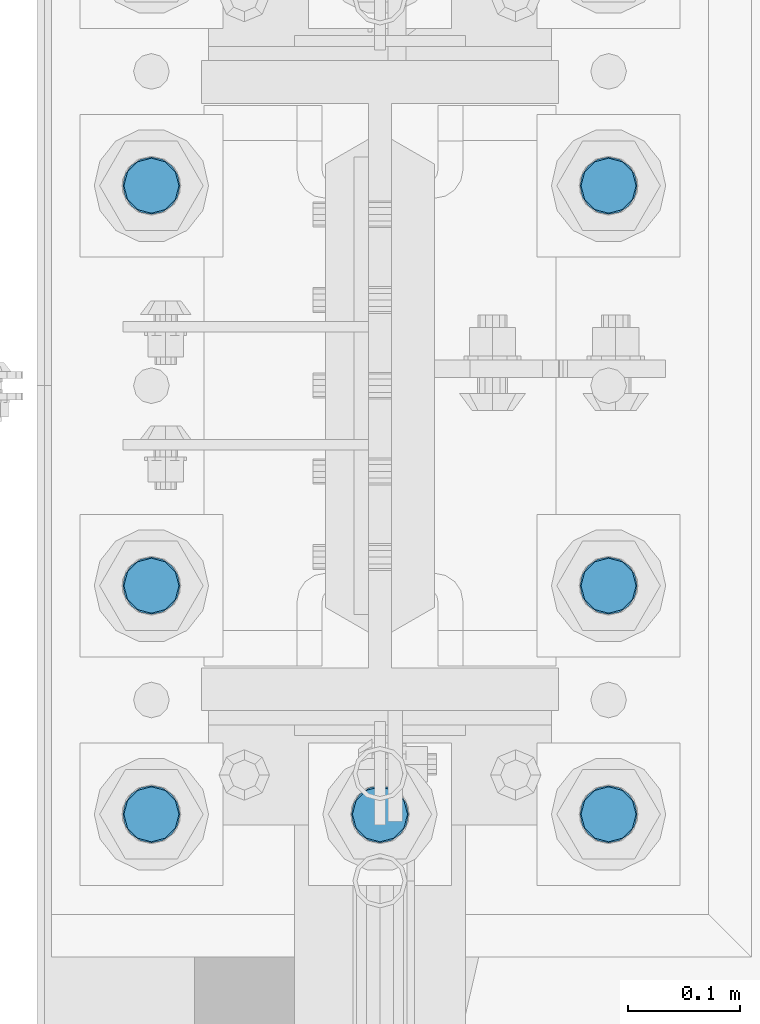
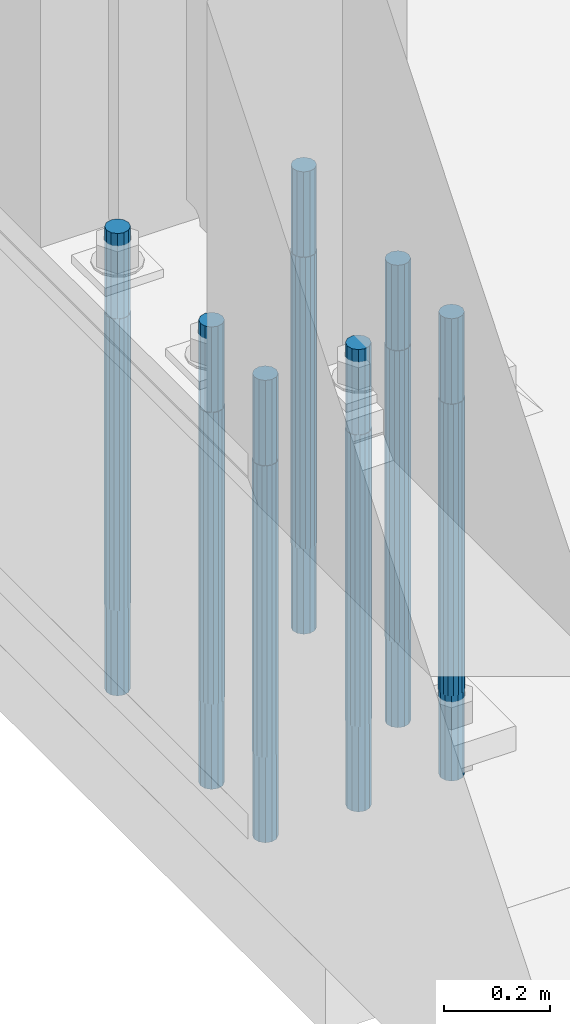
# One storey, part 731 of 1876: 7 columns, 1 element without a shape of its own.
"""IFC2X3 building model written with IfcOpenShell, lengths in millimetres."""

from ifc_helpers import new_model, si_unit, frame, origin_with_axes, place, context, subcontext, project, spatial, faceted_brep, material, type_object, element, aggregate, save


model = new_model("IFC2X3")

# Units and contexts
model_context = context("Model", 3, precision=1e-05, world=origin_with_axes())
body_context = subcontext(model_context, "Body", "Model", "MODEL_VIEW")
ifc_project = project(units=[si_unit("LENGTHUNIT", "METRE", prefix="MILLI"), si_unit("AREAUNIT", "SQUARE_METRE"), si_unit("VOLUMEUNIT", "CUBIC_METRE"), si_unit("MASSUNIT", "GRAM", prefix="KILO"), si_unit("TIMEUNIT", "SECOND"), si_unit("PLANEANGLEUNIT", "RADIAN"), si_unit("SOLIDANGLEUNIT", "STERADIAN"), si_unit("THERMODYNAMICTEMPERATUREUNIT", "DEGREE_CELSIUS"), si_unit("LUMINOUSINTENSITYUNIT", "LUMEN")], contexts=[model_context])

# Site, building, storey
site_placement = place(None, origin_with_axes())
site = spatial("IfcSite", under=ifc_project, at=site_placement, CompositionType="ELEMENT")
building_placement = place(site_placement, origin_with_axes())
building = spatial("IfcBuilding", under=site, at=building_placement, Name="Undefined", CompositionType="ELEMENT")
storey_placement = place(building_placement, origin_with_axes())
storey = spatial("IfcBuildingStorey", under=building, at=storey_placement, Name="Undefined", CompositionType="ELEMENT", Elevation=0.0)

# Assembly, columns
assembly_placement = place(storey_placement, origin_with_axes())
assembly = element("IfcElementAssembly", 1, at=assembly_placement, inside=storey, Name="TEMPLATE", AssemblyPlace="NOTDEFINED", PredefinedType="RIGID_FRAME")
ifc_material = material(Name="STEEL/F1554-GR.105")
column_type = type_object("IfcColumnType", PredefinedType="NOTDEFINED")
column_1_placement = place(assembly_placement, frame((-203.2, 7239.0, 0.0), z_axis=(0.0, -1.0, 0.0), x_axis=(0.0, 0.0, -1.0)))
column_1 = element("IfcColumn", 2, at=column_1_placement, type_object=column_type, material=ifc_material, Name="ANCHOR_BOLTS", context=body_context, shape_type="Brep", body=[
    faceted_brep([(-196.85, -21.217622392719, 12.25), (-196.85, -12.25, 21.2176223927188), (-196.85, 0.0, 24.5), (-196.85, 12.25, 21.2176223927188), (-196.85, 21.217622392719, 12.25), (-196.85, 24.5, 0.0), (-196.85, 21.217622392719, -12.25), (-196.85, 12.25, -21.2176223927188), (-196.85, 0.0, -24.5), (-196.85, -12.25, -21.2176223927188), (-196.85, -21.217622392719, -12.25), (-196.85, -24.5, 0.0), (0.0, 24.5, 0.0), (0.0, 21.217622392719, -12.25), (0.0, 12.25, -21.2176223927188), (0.0, 0.0, -24.5), (0.0, -12.25, -21.2176223927188), (0.0, -21.217622392719, -12.25), (0.0, -24.5, 0.0), (0.0, -21.217622392719, 12.25), (0.0, -12.25, 21.2176223927188), (0.0, 0.0, 24.5), (0.0, 12.25, 21.2176223927188), (0.0, 21.217622392719, 12.25), (0.0, -23.4665401257871, 9.7201591820733), (0.0, -17.9605122421381, 17.9605122421383), (0.0, -9.72015918207308, 23.4665401257867), (0.0, 0.0, 25.4000000000001), (0.0, 9.72015918207308, 23.4665401257867), (0.0, 17.9605122421381, 17.9605122421383), (0.0, 23.4665401257871, 9.7201591820733), (0.0, 25.3999996185339, 9.09494701772928e-13), (0.0, 23.4665401257871, -9.7201591820733), (0.0, 17.9605122421381, -17.9605122421383), (0.0, 9.72015918207308, -23.4665401257867), (0.0, 0.0, -25.4000000000001), (0.0, -9.72015918207308, -23.4665401257867), (0.0, -17.9605122421381, -17.9605122421383), (0.0, -23.4665401257871, -9.7201591820733), (0.0, -25.3999996185375, 0.0), (673.1, -25.3999999999996, 0.0), (673.1, -23.4665401257871, 9.7201591820733), (673.1, -17.9605122421381, 17.9605122421383), (673.1, -9.72015918207308, 23.4665401257867), (673.1, 0.0, 25.4000000000001), (673.1, 9.72015918207308, 23.4665401257867), (673.1, 17.9605122421381, 17.9605122421383), (673.1, 23.4665401257871, 9.7201591820733), (673.1, 25.3999999999996, 0.0), (673.1, 23.4665401257871, -9.7201591820733), (673.1, 17.9605122421381, -17.9605122421383), (673.1, 9.72015918207308, -23.4665401257867), (673.1, 0.0, -25.4000000000001), (673.1, -9.72015918207308, -23.4665401257867), (673.1, -17.9605122421381, -17.9605122421383), (673.1, -23.4665401257871, -9.7201591820733), (673.1, -12.25, 21.2176223927188), (673.1, 0.0, 24.5), (673.1, 12.25, 21.2176223927188), (673.1, 21.217622392719, 12.25), (673.1, 24.5, 0.0), (673.1, 21.217622392719, -12.25), (673.1, 12.25, -21.2176223927188), (673.1, 0.0, -24.5), (673.1, -12.25, -21.2176223927188), (673.1, -21.217622392719, -12.25), (673.1, -24.5, 0.0), (673.1, -21.217622392719, 12.25), (869.95, -12.25, -21.2176223927188), (869.95, 0.0, -24.5), (869.95, 12.25, -21.2176223927188), (869.95, 21.217622392719, -12.25), (869.95, 24.5, 0.0), (869.95, 21.217622392719, 12.25), (869.95, 12.25, 21.2176223927188), (869.95, 0.0, 24.5), (869.95, -12.25, 21.2176223927188), (869.95, -21.217622392719, 12.25), (869.95, -24.5, 0.0), (869.95, -21.217622392719, -12.25)], [[[0, 1, 2, 3, 4, 5, 6, 7, 8, 9, 10, 11]], [[6, 5, 12, 13]], [[7, 6, 13, 14]], [[8, 7, 14, 15]], [[9, 8, 15, 16]], [[10, 9, 16, 17]], [[11, 10, 17, 18]], [[0, 11, 18, 19]], [[1, 0, 19, 20]], [[2, 1, 20, 21]], [[3, 2, 21, 22]], [[4, 3, 22, 23]], [[5, 4, 23, 12]], [[24, 25, 26, 27, 28, 29, 30, 31, 32, 33, 34, 35, 36, 37, 38, 39], [22, 21, 20, 19, 18, 17, 16, 15, 14, 13, 12, 23]], [[24, 39, 40, 41]], [[25, 24, 41, 42]], [[26, 25, 42, 43]], [[27, 26, 43, 44]], [[28, 27, 44, 45]], [[29, 28, 45, 46]], [[30, 29, 46, 47]], [[31, 30, 47, 48]], [[32, 31, 48, 49]], [[33, 32, 49, 50]], [[34, 33, 50, 51]], [[35, 34, 51, 52]], [[36, 35, 52, 53]], [[37, 36, 53, 54]], [[38, 37, 54, 55]], [[39, 38, 55, 40]], [[54, 53, 52, 51, 50, 49, 48, 47, 46, 45, 44, 43, 42, 41, 40, 55], [56, 57, 58, 59, 60, 61, 62, 63, 64, 65, 66, 67]], [[68, 69, 70, 71, 72, 73, 74, 75, 76, 77, 78, 79]], [[76, 75, 57, 56]], [[77, 76, 56, 67]], [[78, 77, 67, 66]], [[79, 78, 66, 65]], [[68, 79, 65, 64]], [[69, 68, 64, 63]], [[70, 69, 63, 62]], [[71, 70, 62, 61]], [[72, 71, 61, 60]], [[73, 72, 60, 59]], [[74, 73, 59, 58]], [[75, 74, 58, 57]]]),
])
column_2_placement = place(assembly_placement, frame((0.0, 7239.0, 0.0), z_axis=(0.0, -1.0, 0.0), x_axis=(0.0, 0.0, -1.0)))
column_2 = element("IfcColumn", 3, at=column_2_placement, type_object=column_type, material=ifc_material, Name="ANCHOR_BOLTS", context=body_context, shape_type="Brep", body=[
    faceted_brep([(-196.85, -21.217622392719, 12.25), (-196.85, -12.25, 21.2176223927188), (-196.85, 0.0, 24.5), (-196.85, 12.25, 21.2176223927188), (-196.85, 21.217622392719, 12.25), (-196.85, 24.5, 0.0), (-196.85, 21.217622392719, -12.25), (-196.85, 12.25, -21.2176223927188), (-196.85, 0.0, -24.5), (-196.85, -12.25, -21.2176223927188), (-196.85, -21.217622392719, -12.25), (-196.85, -24.5, 0.0), (0.0, 24.5, 0.0), (0.0, 21.217622392719, -12.25), (0.0, 12.25, -21.2176223927188), (0.0, 0.0, -24.5), (0.0, -12.25, -21.2176223927188), (0.0, -21.217622392719, -12.25), (0.0, -24.5, 0.0), (0.0, -21.217622392719, 12.25), (0.0, -12.25, 21.2176223927188), (0.0, 0.0, 24.5), (0.0, 12.25, 21.2176223927188), (0.0, 21.217622392719, 12.25), (0.0, -23.4665401257871, 9.7201591820733), (0.0, -17.9605122421381, 17.9605122421383), (0.0, -9.72015918207308, 23.4665401257867), (0.0, 0.0, 25.4000000000001), (0.0, 9.72015918207308, 23.4665401257867), (0.0, 17.9605122421381, 17.9605122421383), (0.0, 23.4665401257871, 9.7201591820733), (0.0, 25.3999996185339, 9.09494701772928e-13), (0.0, 23.4665401257871, -9.7201591820733), (0.0, 17.9605122421381, -17.9605122421383), (0.0, 9.72015918207308, -23.4665401257867), (0.0, 0.0, -25.4000000000001), (0.0, -9.72015918207308, -23.4665401257867), (0.0, -17.9605122421381, -17.9605122421383), (0.0, -23.4665401257871, -9.7201591820733), (0.0, -25.3999996185375, 0.0), (673.1, -25.3999999999996, 0.0), (673.1, -23.4665401257871, 9.7201591820733), (673.1, -17.9605122421381, 17.9605122421383), (673.1, -9.72015918207308, 23.4665401257867), (673.1, 0.0, 25.4000000000001), (673.1, 9.72015918207308, 23.4665401257867), (673.1, 17.9605122421381, 17.9605122421383), (673.1, 23.4665401257871, 9.7201591820733), (673.1, 25.3999999999996, 0.0), (673.1, 23.4665401257871, -9.7201591820733), (673.1, 17.9605122421381, -17.9605122421383), (673.1, 9.72015918207308, -23.4665401257867), (673.1, 0.0, -25.4000000000001), (673.1, -9.72015918207308, -23.4665401257867), (673.1, -17.9605122421381, -17.9605122421383), (673.1, -23.4665401257871, -9.7201591820733), (673.1, -12.25, 21.2176223927188), (673.1, 0.0, 24.5), (673.1, 12.25, 21.2176223927188), (673.1, 21.217622392719, 12.25), (673.1, 24.5, 0.0), (673.1, 21.217622392719, -12.25), (673.1, 12.25, -21.2176223927188), (673.1, 0.0, -24.5), (673.1, -12.25, -21.2176223927188), (673.1, -21.217622392719, -12.25), (673.1, -24.5, 0.0), (673.1, -21.217622392719, 12.25), (869.95, -12.25, -21.2176223927188), (869.95, 0.0, -24.5), (869.95, 12.25, -21.2176223927188), (869.95, 21.217622392719, -12.25), (869.95, 24.5, 0.0), (869.95, 21.217622392719, 12.25), (869.95, 12.25, 21.2176223927188), (869.95, 0.0, 24.5), (869.95, -12.25, 21.2176223927188), (869.95, -21.217622392719, 12.25), (869.95, -24.5, 0.0), (869.95, -21.217622392719, -12.25)], [[[0, 1, 2, 3, 4, 5, 6, 7, 8, 9, 10, 11]], [[6, 5, 12, 13]], [[7, 6, 13, 14]], [[8, 7, 14, 15]], [[9, 8, 15, 16]], [[10, 9, 16, 17]], [[11, 10, 17, 18]], [[0, 11, 18, 19]], [[1, 0, 19, 20]], [[2, 1, 20, 21]], [[3, 2, 21, 22]], [[4, 3, 22, 23]], [[5, 4, 23, 12]], [[24, 25, 26, 27, 28, 29, 30, 31, 32, 33, 34, 35, 36, 37, 38, 39], [22, 21, 20, 19, 18, 17, 16, 15, 14, 13, 12, 23]], [[24, 39, 40, 41]], [[25, 24, 41, 42]], [[26, 25, 42, 43]], [[27, 26, 43, 44]], [[28, 27, 44, 45]], [[29, 28, 45, 46]], [[30, 29, 46, 47]], [[31, 30, 47, 48]], [[32, 31, 48, 49]], [[33, 32, 49, 50]], [[34, 33, 50, 51]], [[35, 34, 51, 52]], [[36, 35, 52, 53]], [[37, 36, 53, 54]], [[38, 37, 54, 55]], [[39, 38, 55, 40]], [[54, 53, 52, 51, 50, 49, 48, 47, 46, 45, 44, 43, 42, 41, 40, 55], [56, 57, 58, 59, 60, 61, 62, 63, 64, 65, 66, 67]], [[68, 69, 70, 71, 72, 73, 74, 75, 76, 77, 78, 79]], [[76, 75, 57, 56]], [[77, 76, 56, 67]], [[78, 77, 67, 66]], [[79, 78, 66, 65]], [[68, 79, 65, 64]], [[69, 68, 64, 63]], [[70, 69, 63, 62]], [[71, 70, 62, 61]], [[72, 71, 61, 60]], [[73, 72, 60, 59]], [[74, 73, 59, 58]], [[75, 74, 58, 57]]]),
])
column_3_placement = place(assembly_placement, frame((203.2, 7239.0, 0.0), z_axis=(0.0, 1.0, 0.0), x_axis=(0.0, 0.0, -1.0)))
column_3 = element("IfcColumn", 4, at=column_3_placement, type_object=column_type, material=ifc_material, Name="ANCHOR_BOLTS", context=body_context, shape_type="Brep", body=[
    faceted_brep([(-196.85, -21.217622392719, 12.25), (-196.85, -12.25, 21.2176223927188), (-196.85, 0.0, 24.5), (-196.85, 12.25, 21.2176223927188), (-196.85, 21.217622392719, 12.25), (-196.85, 24.5, 0.0), (-196.85, 21.217622392719, -12.25), (-196.85, 12.25, -21.2176223927188), (-196.85, 0.0, -24.5), (-196.85, -12.25, -21.2176223927188), (-196.85, -21.217622392719, -12.25), (-196.85, -24.5, 0.0), (0.0, 24.5, 0.0), (0.0, 21.217622392719, -12.25), (0.0, 12.25, -21.2176223927188), (0.0, 0.0, -24.5), (0.0, -12.25, -21.2176223927188), (0.0, -21.217622392719, -12.25), (0.0, -24.5, 0.0), (0.0, -21.217622392719, 12.25), (0.0, -12.25, 21.2176223927188), (0.0, 0.0, 24.5), (0.0, 12.25, 21.2176223927188), (0.0, 21.217622392719, 12.25), (0.0, -23.4665401257871, 9.7201591820733), (0.0, -17.9605122421381, 17.9605122421383), (0.0, -9.72015918207308, 23.4665401257867), (0.0, 0.0, 25.4000000000001), (0.0, 9.72015918207308, 23.4665401257867), (0.0, 17.9605122421381, 17.9605122421383), (0.0, 23.4665401257871, 9.7201591820733), (0.0, 25.3999996185339, 9.09494701772928e-13), (0.0, 23.4665401257871, -9.7201591820733), (0.0, 17.9605122421381, -17.9605122421383), (0.0, 9.72015918207308, -23.4665401257867), (0.0, 0.0, -25.4000000000001), (0.0, -9.72015918207308, -23.4665401257867), (0.0, -17.9605122421381, -17.9605122421383), (0.0, -23.4665401257871, -9.7201591820733), (0.0, -25.3999996185375, 0.0), (673.1, -25.3999999999996, 0.0), (673.1, -23.4665401257871, 9.7201591820733), (673.1, -17.9605122421381, 17.9605122421383), (673.1, -9.72015918207308, 23.4665401257867), (673.1, 0.0, 25.4000000000001), (673.1, 9.72015918207308, 23.4665401257867), (673.1, 17.9605122421381, 17.9605122421383), (673.1, 23.4665401257871, 9.7201591820733), (673.1, 25.3999999999996, 0.0), (673.1, 23.4665401257871, -9.7201591820733), (673.1, 17.9605122421381, -17.9605122421383), (673.1, 9.72015918207308, -23.4665401257867), (673.1, 0.0, -25.4000000000001), (673.1, -9.72015918207308, -23.4665401257867), (673.1, -17.9605122421381, -17.9605122421383), (673.1, -23.4665401257871, -9.7201591820733), (673.1, -12.25, 21.2176223927188), (673.1, 0.0, 24.5), (673.1, 12.25, 21.2176223927188), (673.1, 21.217622392719, 12.25), (673.1, 24.5, 0.0), (673.1, 21.217622392719, -12.25), (673.1, 12.25, -21.2176223927188), (673.1, 0.0, -24.5), (673.1, -12.25, -21.2176223927188), (673.1, -21.217622392719, -12.25), (673.1, -24.5, 0.0), (673.1, -21.217622392719, 12.25), (869.95, -12.25, -21.2176223927188), (869.95, 0.0, -24.5), (869.95, 12.25, -21.2176223927188), (869.95, 21.217622392719, -12.25), (869.95, 24.5, 0.0), (869.95, 21.217622392719, 12.25), (869.95, 12.25, 21.2176223927188), (869.95, 0.0, 24.5), (869.95, -12.25, 21.2176223927188), (869.95, -21.217622392719, 12.25), (869.95, -24.5, 0.0), (869.95, -21.217622392719, -12.25)], [[[0, 1, 2, 3, 4, 5, 6, 7, 8, 9, 10, 11]], [[6, 5, 12, 13]], [[7, 6, 13, 14]], [[8, 7, 14, 15]], [[9, 8, 15, 16]], [[10, 9, 16, 17]], [[11, 10, 17, 18]], [[0, 11, 18, 19]], [[1, 0, 19, 20]], [[2, 1, 20, 21]], [[3, 2, 21, 22]], [[4, 3, 22, 23]], [[5, 4, 23, 12]], [[24, 25, 26, 27, 28, 29, 30, 31, 32, 33, 34, 35, 36, 37, 38, 39], [22, 21, 20, 19, 18, 17, 16, 15, 14, 13, 12, 23]], [[24, 39, 40, 41]], [[25, 24, 41, 42]], [[26, 25, 42, 43]], [[27, 26, 43, 44]], [[28, 27, 44, 45]], [[29, 28, 45, 46]], [[30, 29, 46, 47]], [[31, 30, 47, 48]], [[32, 31, 48, 49]], [[33, 32, 49, 50]], [[34, 33, 50, 51]], [[35, 34, 51, 52]], [[36, 35, 52, 53]], [[37, 36, 53, 54]], [[38, 37, 54, 55]], [[39, 38, 55, 40]], [[54, 53, 52, 51, 50, 49, 48, 47, 46, 45, 44, 43, 42, 41, 40, 55], [56, 57, 58, 59, 60, 61, 62, 63, 64, 65, 66, 67]], [[68, 69, 70, 71, 72, 73, 74, 75, 76, 77, 78, 79]], [[76, 75, 57, 56]], [[77, 76, 56, 67]], [[78, 77, 67, 66]], [[79, 78, 66, 65]], [[68, 79, 65, 64]], [[69, 68, 64, 63]], [[70, 69, 63, 62]], [[71, 70, 62, 61]], [[72, 71, 61, 60]], [[73, 72, 60, 59]], [[74, 73, 59, 58]], [[75, 74, 58, 57]]]),
])
column_4_placement = place(assembly_placement, frame((-203.2, 7442.2, 0.0), z_axis=(0.0, -1.0, 0.0), x_axis=(0.0, 0.0, -1.0)))
column_4 = element("IfcColumn", 5, at=column_4_placement, type_object=column_type, material=ifc_material, Name="ANCHOR_BOLTS", context=body_context, shape_type="Brep", body=[
    faceted_brep([(-196.85, -21.217622392719, 12.25), (-196.85, -12.25, 21.2176223927188), (-196.85, 0.0, 24.5), (-196.85, 12.25, 21.2176223927188), (-196.85, 21.217622392719, 12.25), (-196.85, 24.5, 0.0), (-196.85, 21.217622392719, -12.25), (-196.85, 12.25, -21.2176223927188), (-196.85, 0.0, -24.5), (-196.85, -12.25, -21.2176223927188), (-196.85, -21.217622392719, -12.25), (-196.85, -24.5, 0.0), (0.0, 24.5, 0.0), (0.0, 21.217622392719, -12.25), (0.0, 12.25, -21.2176223927188), (0.0, 0.0, -24.5), (0.0, -12.25, -21.2176223927188), (0.0, -21.217622392719, -12.25), (0.0, -24.5, 0.0), (0.0, -21.217622392719, 12.25), (0.0, -12.25, 21.2176223927188), (0.0, 0.0, 24.5), (0.0, 12.25, 21.2176223927188), (0.0, 21.217622392719, 12.25), (0.0, -23.4665401257871, 9.7201591820733), (0.0, -17.9605122421381, 17.9605122421383), (0.0, -9.72015918207308, 23.4665401257867), (0.0, 0.0, 25.4000000000001), (0.0, 9.72015918207308, 23.4665401257867), (0.0, 17.9605122421381, 17.9605122421383), (0.0, 23.4665401257871, 9.7201591820733), (0.0, 25.3999996185339, 9.09494701772928e-13), (0.0, 23.4665401257871, -9.7201591820733), (0.0, 17.9605122421381, -17.9605122421383), (0.0, 9.72015918207308, -23.4665401257867), (0.0, 0.0, -25.4000000000001), (0.0, -9.72015918207308, -23.4665401257867), (0.0, -17.9605122421381, -17.9605122421383), (0.0, -23.4665401257871, -9.7201591820733), (0.0, -25.3999996185375, 0.0), (673.1, -25.3999999999996, 0.0), (673.1, -23.4665401257871, 9.7201591820733), (673.1, -17.9605122421381, 17.9605122421383), (673.1, -9.72015918207308, 23.4665401257867), (673.1, 0.0, 25.4000000000001), (673.1, 9.72015918207308, 23.4665401257867), (673.1, 17.9605122421381, 17.9605122421383), (673.1, 23.4665401257871, 9.7201591820733), (673.1, 25.3999999999996, 0.0), (673.1, 23.4665401257871, -9.7201591820733), (673.1, 17.9605122421381, -17.9605122421383), (673.1, 9.72015918207308, -23.4665401257867), (673.1, 0.0, -25.4000000000001), (673.1, -9.72015918207308, -23.4665401257867), (673.1, -17.9605122421381, -17.9605122421383), (673.1, -23.4665401257871, -9.7201591820733), (673.1, -12.25, 21.2176223927188), (673.1, 0.0, 24.5), (673.1, 12.25, 21.2176223927188), (673.1, 21.217622392719, 12.25), (673.1, 24.5, 0.0), (673.1, 21.217622392719, -12.25), (673.1, 12.25, -21.2176223927188), (673.1, 0.0, -24.5), (673.1, -12.25, -21.2176223927188), (673.1, -21.217622392719, -12.25), (673.1, -24.5, 0.0), (673.1, -21.217622392719, 12.25), (869.95, -12.25, -21.2176223927188), (869.95, 0.0, -24.5), (869.95, 12.25, -21.2176223927188), (869.95, 21.217622392719, -12.25), (869.95, 24.5, 0.0), (869.95, 21.217622392719, 12.25), (869.95, 12.25, 21.2176223927188), (869.95, 0.0, 24.5), (869.95, -12.25, 21.2176223927188), (869.95, -21.217622392719, 12.25), (869.95, -24.5, 0.0), (869.95, -21.217622392719, -12.25)], [[[0, 1, 2, 3, 4, 5, 6, 7, 8, 9, 10, 11]], [[6, 5, 12, 13]], [[7, 6, 13, 14]], [[8, 7, 14, 15]], [[9, 8, 15, 16]], [[10, 9, 16, 17]], [[11, 10, 17, 18]], [[0, 11, 18, 19]], [[1, 0, 19, 20]], [[2, 1, 20, 21]], [[3, 2, 21, 22]], [[4, 3, 22, 23]], [[5, 4, 23, 12]], [[24, 25, 26, 27, 28, 29, 30, 31, 32, 33, 34, 35, 36, 37, 38, 39], [22, 21, 20, 19, 18, 17, 16, 15, 14, 13, 12, 23]], [[24, 39, 40, 41]], [[25, 24, 41, 42]], [[26, 25, 42, 43]], [[27, 26, 43, 44]], [[28, 27, 44, 45]], [[29, 28, 45, 46]], [[30, 29, 46, 47]], [[31, 30, 47, 48]], [[32, 31, 48, 49]], [[33, 32, 49, 50]], [[34, 33, 50, 51]], [[35, 34, 51, 52]], [[36, 35, 52, 53]], [[37, 36, 53, 54]], [[38, 37, 54, 55]], [[39, 38, 55, 40]], [[54, 53, 52, 51, 50, 49, 48, 47, 46, 45, 44, 43, 42, 41, 40, 55], [56, 57, 58, 59, 60, 61, 62, 63, 64, 65, 66, 67]], [[68, 69, 70, 71, 72, 73, 74, 75, 76, 77, 78, 79]], [[76, 75, 57, 56]], [[77, 76, 56, 67]], [[78, 77, 67, 66]], [[79, 78, 66, 65]], [[68, 79, 65, 64]], [[69, 68, 64, 63]], [[70, 69, 63, 62]], [[71, 70, 62, 61]], [[72, 71, 61, 60]], [[73, 72, 60, 59]], [[74, 73, 59, 58]], [[75, 74, 58, 57]]]),
])
column_5_placement = place(assembly_placement, frame((203.2, 7442.2, 0.0), z_axis=(0.0, 1.0, 0.0), x_axis=(0.0, 0.0, -1.0)))
column_5 = element("IfcColumn", 6, at=column_5_placement, type_object=column_type, material=ifc_material, Name="ANCHOR_BOLTS", context=body_context, shape_type="Brep", body=[
    faceted_brep([(-196.85, -21.217622392719, 12.25), (-196.85, -12.25, 21.2176223927188), (-196.85, 0.0, 24.5), (-196.85, 12.25, 21.2176223927188), (-196.85, 21.217622392719, 12.25), (-196.85, 24.5, 0.0), (-196.85, 21.217622392719, -12.25), (-196.85, 12.25, -21.2176223927188), (-196.85, 0.0, -24.5), (-196.85, -12.25, -21.2176223927188), (-196.85, -21.217622392719, -12.25), (-196.85, -24.5, 0.0), (0.0, 24.5, 0.0), (0.0, 21.217622392719, -12.25), (0.0, 12.25, -21.2176223927188), (0.0, 0.0, -24.5), (0.0, -12.25, -21.2176223927188), (0.0, -21.217622392719, -12.25), (0.0, -24.5, 0.0), (0.0, -21.217622392719, 12.25), (0.0, -12.25, 21.2176223927188), (0.0, 0.0, 24.5), (0.0, 12.25, 21.2176223927188), (0.0, 21.217622392719, 12.25), (0.0, -23.4665401257871, 9.7201591820733), (0.0, -17.9605122421381, 17.9605122421383), (0.0, -9.72015918207308, 23.4665401257867), (0.0, 0.0, 25.4000000000001), (0.0, 9.72015918207308, 23.4665401257867), (0.0, 17.9605122421381, 17.9605122421383), (0.0, 23.4665401257871, 9.7201591820733), (0.0, 25.3999996185339, 9.09494701772928e-13), (0.0, 23.4665401257871, -9.7201591820733), (0.0, 17.9605122421381, -17.9605122421383), (0.0, 9.72015918207308, -23.4665401257867), (0.0, 0.0, -25.4000000000001), (0.0, -9.72015918207308, -23.4665401257867), (0.0, -17.9605122421381, -17.9605122421383), (0.0, -23.4665401257871, -9.7201591820733), (0.0, -25.3999996185375, 0.0), (673.1, -25.3999999999996, 0.0), (673.1, -23.4665401257871, 9.7201591820733), (673.1, -17.9605122421381, 17.9605122421383), (673.1, -9.72015918207308, 23.4665401257867), (673.1, 0.0, 25.4000000000001), (673.1, 9.72015918207308, 23.4665401257867), (673.1, 17.9605122421381, 17.9605122421383), (673.1, 23.4665401257871, 9.7201591820733), (673.1, 25.3999999999996, 0.0), (673.1, 23.4665401257871, -9.7201591820733), (673.1, 17.9605122421381, -17.9605122421383), (673.1, 9.72015918207308, -23.4665401257867), (673.1, 0.0, -25.4000000000001), (673.1, -9.72015918207308, -23.4665401257867), (673.1, -17.9605122421381, -17.9605122421383), (673.1, -23.4665401257871, -9.7201591820733), (673.1, -12.25, 21.2176223927188), (673.1, 0.0, 24.5), (673.1, 12.25, 21.2176223927188), (673.1, 21.217622392719, 12.25), (673.1, 24.5, 0.0), (673.1, 21.217622392719, -12.25), (673.1, 12.25, -21.2176223927188), (673.1, 0.0, -24.5), (673.1, -12.25, -21.2176223927188), (673.1, -21.217622392719, -12.25), (673.1, -24.5, 0.0), (673.1, -21.217622392719, 12.25), (869.95, -12.25, -21.2176223927188), (869.95, 0.0, -24.5), (869.95, 12.25, -21.2176223927188), (869.95, 21.217622392719, -12.25), (869.95, 24.5, 0.0), (869.95, 21.217622392719, 12.25), (869.95, 12.25, 21.2176223927188), (869.95, 0.0, 24.5), (869.95, -12.25, 21.2176223927188), (869.95, -21.217622392719, 12.25), (869.95, -24.5, 0.0), (869.95, -21.217622392719, -12.25)], [[[0, 1, 2, 3, 4, 5, 6, 7, 8, 9, 10, 11]], [[6, 5, 12, 13]], [[7, 6, 13, 14]], [[8, 7, 14, 15]], [[9, 8, 15, 16]], [[10, 9, 16, 17]], [[11, 10, 17, 18]], [[0, 11, 18, 19]], [[1, 0, 19, 20]], [[2, 1, 20, 21]], [[3, 2, 21, 22]], [[4, 3, 22, 23]], [[5, 4, 23, 12]], [[24, 25, 26, 27, 28, 29, 30, 31, 32, 33, 34, 35, 36, 37, 38, 39], [22, 21, 20, 19, 18, 17, 16, 15, 14, 13, 12, 23]], [[24, 39, 40, 41]], [[25, 24, 41, 42]], [[26, 25, 42, 43]], [[27, 26, 43, 44]], [[28, 27, 44, 45]], [[29, 28, 45, 46]], [[30, 29, 46, 47]], [[31, 30, 47, 48]], [[32, 31, 48, 49]], [[33, 32, 49, 50]], [[34, 33, 50, 51]], [[35, 34, 51, 52]], [[36, 35, 52, 53]], [[37, 36, 53, 54]], [[38, 37, 54, 55]], [[39, 38, 55, 40]], [[54, 53, 52, 51, 50, 49, 48, 47, 46, 45, 44, 43, 42, 41, 40, 55], [56, 57, 58, 59, 60, 61, 62, 63, 64, 65, 66, 67]], [[68, 69, 70, 71, 72, 73, 74, 75, 76, 77, 78, 79]], [[76, 75, 57, 56]], [[77, 76, 56, 67]], [[78, 77, 67, 66]], [[79, 78, 66, 65]], [[68, 79, 65, 64]], [[69, 68, 64, 63]], [[70, 69, 63, 62]], [[71, 70, 62, 61]], [[72, 71, 61, 60]], [[73, 72, 60, 59]], [[74, 73, 59, 58]], [[75, 74, 58, 57]]]),
])
column_6_placement = place(assembly_placement, frame((-203.2, 7797.8, 0.0), z_axis=(0.0, -1.0, 0.0), x_axis=(0.0, 0.0, -1.0)))
column_6 = element("IfcColumn", 7, at=column_6_placement, type_object=column_type, material=ifc_material, Name="ANCHOR_BOLTS", context=body_context, shape_type="Brep", body=[
    faceted_brep([(-196.85, -21.217622392719, 12.25), (-196.85, -12.25, 21.2176223927188), (-196.85, 0.0, 24.5), (-196.85, 12.25, 21.2176223927188), (-196.85, 21.217622392719, 12.25), (-196.85, 24.5, 0.0), (-196.85, 21.217622392719, -12.25), (-196.85, 12.25, -21.2176223927188), (-196.85, 0.0, -24.5), (-196.85, -12.25, -21.2176223927188), (-196.85, -21.217622392719, -12.25), (-196.85, -24.5, 0.0), (0.0, 24.5, 0.0), (0.0, 21.217622392719, -12.25), (0.0, 12.25, -21.2176223927188), (0.0, 0.0, -24.5), (0.0, -12.25, -21.2176223927188), (0.0, -21.217622392719, -12.25), (0.0, -24.5, 0.0), (0.0, -21.217622392719, 12.25), (0.0, -12.25, 21.2176223927188), (0.0, 0.0, 24.5), (0.0, 12.25, 21.2176223927188), (0.0, 21.217622392719, 12.25), (0.0, -23.4665401257871, 9.7201591820733), (0.0, -17.9605122421381, 17.9605122421383), (0.0, -9.72015918207308, 23.4665401257867), (0.0, 0.0, 25.4000000000001), (0.0, 9.72015918207308, 23.4665401257867), (0.0, 17.9605122421381, 17.9605122421383), (0.0, 23.4665401257871, 9.7201591820733), (0.0, 25.3999996185339, 9.09494701772928e-13), (0.0, 23.4665401257871, -9.7201591820733), (0.0, 17.9605122421381, -17.9605122421383), (0.0, 9.72015918207308, -23.4665401257867), (0.0, 0.0, -25.4000000000001), (0.0, -9.72015918207308, -23.4665401257867), (0.0, -17.9605122421381, -17.9605122421383), (0.0, -23.4665401257871, -9.7201591820733), (0.0, -25.3999996185375, 0.0), (673.1, -25.3999999999996, 0.0), (673.1, -23.4665401257871, 9.7201591820733), (673.1, -17.9605122421381, 17.9605122421383), (673.1, -9.72015918207308, 23.4665401257867), (673.1, 0.0, 25.4000000000001), (673.1, 9.72015918207308, 23.4665401257867), (673.1, 17.9605122421381, 17.9605122421383), (673.1, 23.4665401257871, 9.7201591820733), (673.1, 25.3999999999996, 0.0), (673.1, 23.4665401257871, -9.7201591820733), (673.1, 17.9605122421381, -17.9605122421383), (673.1, 9.72015918207308, -23.4665401257867), (673.1, 0.0, -25.4000000000001), (673.1, -9.72015918207308, -23.4665401257867), (673.1, -17.9605122421381, -17.9605122421383), (673.1, -23.4665401257871, -9.7201591820733), (673.1, -12.25, 21.2176223927188), (673.1, 0.0, 24.5), (673.1, 12.25, 21.2176223927188), (673.1, 21.217622392719, 12.25), (673.1, 24.5, 0.0), (673.1, 21.217622392719, -12.25), (673.1, 12.25, -21.2176223927188), (673.1, 0.0, -24.5), (673.1, -12.25, -21.2176223927188), (673.1, -21.217622392719, -12.25), (673.1, -24.5, 0.0), (673.1, -21.217622392719, 12.25), (869.95, -12.25, -21.2176223927188), (869.95, 0.0, -24.5), (869.95, 12.25, -21.2176223927188), (869.95, 21.217622392719, -12.25), (869.95, 24.5, 0.0), (869.95, 21.217622392719, 12.25), (869.95, 12.25, 21.2176223927188), (869.95, 0.0, 24.5), (869.95, -12.25, 21.2176223927188), (869.95, -21.217622392719, 12.25), (869.95, -24.5, 0.0), (869.95, -21.217622392719, -12.25)], [[[0, 1, 2, 3, 4, 5, 6, 7, 8, 9, 10, 11]], [[6, 5, 12, 13]], [[7, 6, 13, 14]], [[8, 7, 14, 15]], [[9, 8, 15, 16]], [[10, 9, 16, 17]], [[11, 10, 17, 18]], [[0, 11, 18, 19]], [[1, 0, 19, 20]], [[2, 1, 20, 21]], [[3, 2, 21, 22]], [[4, 3, 22, 23]], [[5, 4, 23, 12]], [[24, 25, 26, 27, 28, 29, 30, 31, 32, 33, 34, 35, 36, 37, 38, 39], [22, 21, 20, 19, 18, 17, 16, 15, 14, 13, 12, 23]], [[24, 39, 40, 41]], [[25, 24, 41, 42]], [[26, 25, 42, 43]], [[27, 26, 43, 44]], [[28, 27, 44, 45]], [[29, 28, 45, 46]], [[30, 29, 46, 47]], [[31, 30, 47, 48]], [[32, 31, 48, 49]], [[33, 32, 49, 50]], [[34, 33, 50, 51]], [[35, 34, 51, 52]], [[36, 35, 52, 53]], [[37, 36, 53, 54]], [[38, 37, 54, 55]], [[39, 38, 55, 40]], [[54, 53, 52, 51, 50, 49, 48, 47, 46, 45, 44, 43, 42, 41, 40, 55], [56, 57, 58, 59, 60, 61, 62, 63, 64, 65, 66, 67]], [[68, 69, 70, 71, 72, 73, 74, 75, 76, 77, 78, 79]], [[76, 75, 57, 56]], [[77, 76, 56, 67]], [[78, 77, 67, 66]], [[79, 78, 66, 65]], [[68, 79, 65, 64]], [[69, 68, 64, 63]], [[70, 69, 63, 62]], [[71, 70, 62, 61]], [[72, 71, 61, 60]], [[73, 72, 60, 59]], [[74, 73, 59, 58]], [[75, 74, 58, 57]]]),
])
column_7_placement = place(assembly_placement, frame((203.2, 7797.8, 0.0), z_axis=(0.0, 1.0, 0.0), x_axis=(0.0, 0.0, -1.0)))
column_7 = element("IfcColumn", 8, at=column_7_placement, type_object=column_type, material=ifc_material, Name="ANCHOR_BOLTS", context=body_context, shape_type="Brep", body=[
    faceted_brep([(-196.85, -21.217622392719, 12.25), (-196.85, -12.25, 21.2176223927188), (-196.85, 0.0, 24.5), (-196.85, 12.25, 21.2176223927188), (-196.85, 21.217622392719, 12.25), (-196.85, 24.5, 0.0), (-196.85, 21.217622392719, -12.25), (-196.85, 12.25, -21.2176223927188), (-196.85, 0.0, -24.5), (-196.85, -12.25, -21.2176223927188), (-196.85, -21.217622392719, -12.25), (-196.85, -24.5, 0.0), (0.0, 24.5, 0.0), (0.0, 21.217622392719, -12.25), (0.0, 12.25, -21.2176223927188), (0.0, 0.0, -24.5), (0.0, -12.25, -21.2176223927188), (0.0, -21.217622392719, -12.25), (0.0, -24.5, 0.0), (0.0, -21.217622392719, 12.25), (0.0, -12.25, 21.2176223927188), (0.0, 0.0, 24.5), (0.0, 12.25, 21.2176223927188), (0.0, 21.217622392719, 12.25), (0.0, -23.4665401257871, 9.7201591820733), (0.0, -17.9605122421381, 17.9605122421383), (0.0, -9.72015918207308, 23.4665401257867), (0.0, 0.0, 25.4000000000001), (0.0, 9.72015918207308, 23.4665401257867), (0.0, 17.9605122421381, 17.9605122421383), (0.0, 23.4665401257871, 9.7201591820733), (0.0, 25.3999996185339, 9.09494701772928e-13), (0.0, 23.4665401257871, -9.7201591820733), (0.0, 17.9605122421381, -17.9605122421383), (0.0, 9.72015918207308, -23.4665401257867), (0.0, 0.0, -25.4000000000001), (0.0, -9.72015918207308, -23.4665401257867), (0.0, -17.9605122421381, -17.9605122421383), (0.0, -23.4665401257871, -9.7201591820733), (0.0, -25.3999996185375, 0.0), (673.1, -25.3999999999996, 0.0), (673.1, -23.4665401257871, 9.7201591820733), (673.1, -17.9605122421381, 17.9605122421383), (673.1, -9.72015918207308, 23.4665401257867), (673.1, 0.0, 25.4000000000001), (673.1, 9.72015918207308, 23.4665401257867), (673.1, 17.9605122421381, 17.9605122421383), (673.1, 23.4665401257871, 9.7201591820733), (673.1, 25.3999999999996, 0.0), (673.1, 23.4665401257871, -9.7201591820733), (673.1, 17.9605122421381, -17.9605122421383), (673.1, 9.72015918207308, -23.4665401257867), (673.1, 0.0, -25.4000000000001), (673.1, -9.72015918207308, -23.4665401257867), (673.1, -17.9605122421381, -17.9605122421383), (673.1, -23.4665401257871, -9.7201591820733), (673.1, -12.25, 21.2176223927188), (673.1, 0.0, 24.5), (673.1, 12.25, 21.2176223927188), (673.1, 21.217622392719, 12.25), (673.1, 24.5, 0.0), (673.1, 21.217622392719, -12.25), (673.1, 12.25, -21.2176223927188), (673.1, 0.0, -24.5), (673.1, -12.25, -21.2176223927188), (673.1, -21.217622392719, -12.25), (673.1, -24.5, 0.0), (673.1, -21.217622392719, 12.25), (869.95, -12.25, -21.2176223927188), (869.95, 0.0, -24.5), (869.95, 12.25, -21.2176223927188), (869.95, 21.217622392719, -12.25), (869.95, 24.5, 0.0), (869.95, 21.217622392719, 12.25), (869.95, 12.25, 21.2176223927188), (869.95, 0.0, 24.5), (869.95, -12.25, 21.2176223927188), (869.95, -21.217622392719, 12.25), (869.95, -24.5, 0.0), (869.95, -21.217622392719, -12.25)], [[[0, 1, 2, 3, 4, 5, 6, 7, 8, 9, 10, 11]], [[6, 5, 12, 13]], [[7, 6, 13, 14]], [[8, 7, 14, 15]], [[9, 8, 15, 16]], [[10, 9, 16, 17]], [[11, 10, 17, 18]], [[0, 11, 18, 19]], [[1, 0, 19, 20]], [[2, 1, 20, 21]], [[3, 2, 21, 22]], [[4, 3, 22, 23]], [[5, 4, 23, 12]], [[24, 25, 26, 27, 28, 29, 30, 31, 32, 33, 34, 35, 36, 37, 38, 39], [22, 21, 20, 19, 18, 17, 16, 15, 14, 13, 12, 23]], [[24, 39, 40, 41]], [[25, 24, 41, 42]], [[26, 25, 42, 43]], [[27, 26, 43, 44]], [[28, 27, 44, 45]], [[29, 28, 45, 46]], [[30, 29, 46, 47]], [[31, 30, 47, 48]], [[32, 31, 48, 49]], [[33, 32, 49, 50]], [[34, 33, 50, 51]], [[35, 34, 51, 52]], [[36, 35, 52, 53]], [[37, 36, 53, 54]], [[38, 37, 54, 55]], [[39, 38, 55, 40]], [[54, 53, 52, 51, 50, 49, 48, 47, 46, 45, 44, 43, 42, 41, 40, 55], [56, 57, 58, 59, 60, 61, 62, 63, 64, 65, 66, 67]], [[68, 69, 70, 71, 72, 73, 74, 75, 76, 77, 78, 79]], [[76, 75, 57, 56]], [[77, 76, 56, 67]], [[78, 77, 67, 66]], [[79, 78, 66, 65]], [[68, 79, 65, 64]], [[69, 68, 64, 63]], [[70, 69, 63, 62]], [[71, 70, 62, 61]], [[72, 71, 61, 60]], [[73, 72, 60, 59]], [[74, 73, 59, 58]], [[75, 74, 58, 57]]]),
])
aggregate(assembly, [column_1, column_2, column_3, column_4, column_5, column_6, column_7])

save(model, "model.ifc")
